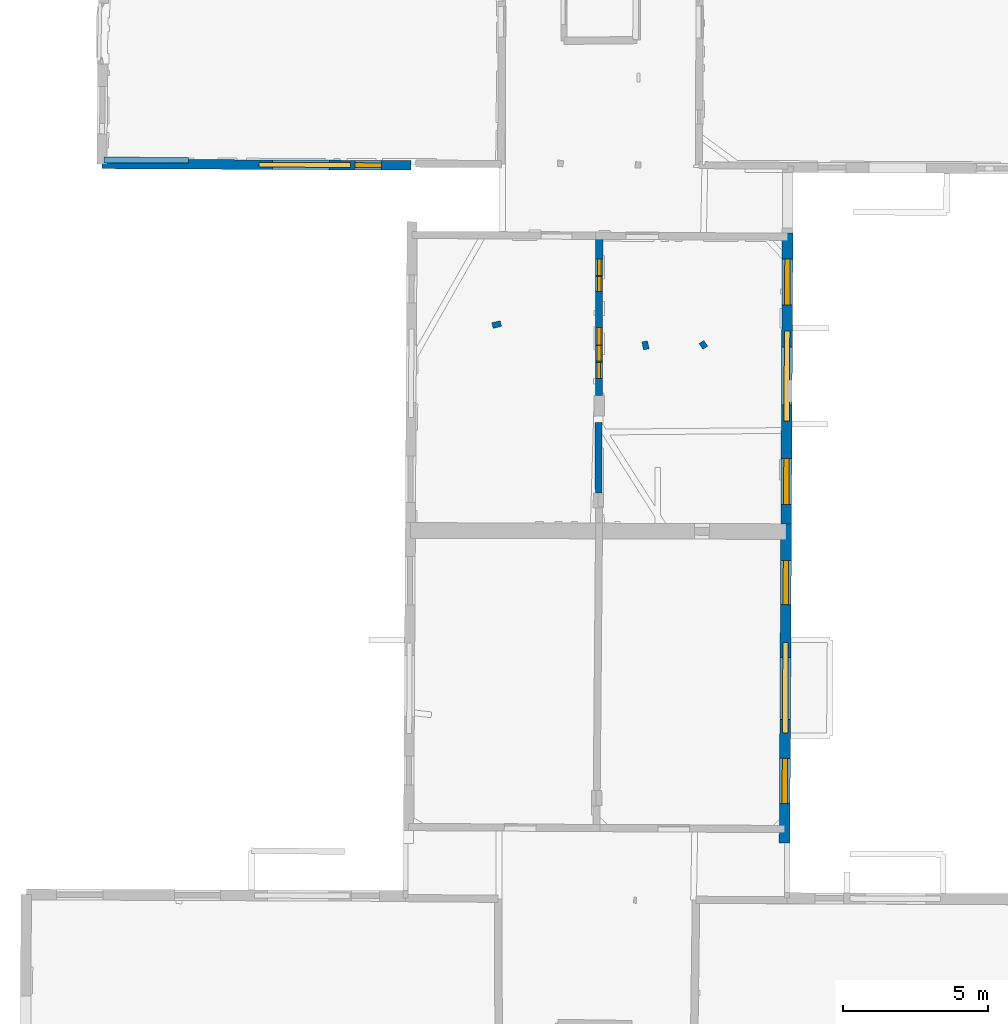
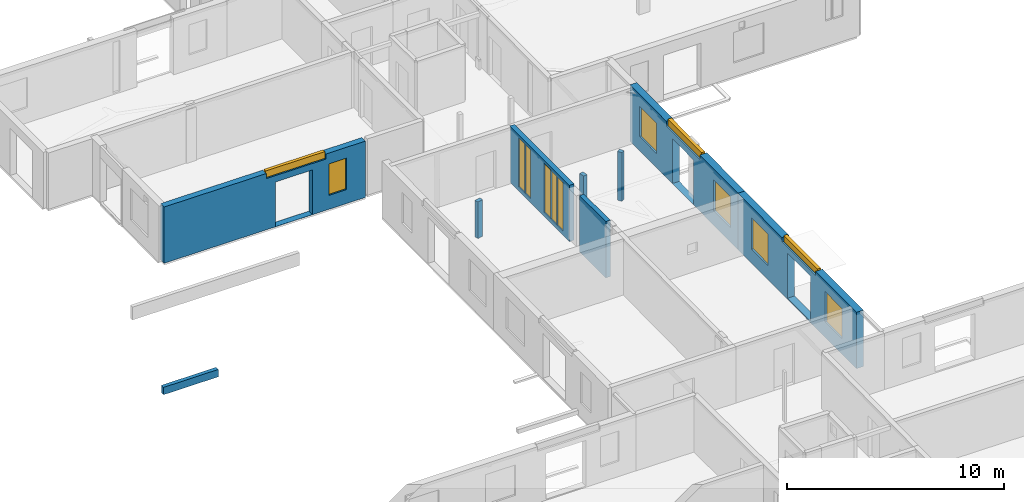
# One storey, part 7 of 17: 13 windows, 9 walls, 16 openings.
"""IFC2X3 building model written with IfcOpenShell, lengths in metres."""

from ifc_helpers import new_model, entity, si_unit, converted_unit, derived_unit, direction, frame, frame_2d, origin, origin_2d_with_axis, place, context, subcontext, project, spatial, polyline, rectangle, outline, extrude, source, transform, mapped, material, layer, layer_set, layer_usage, type_object, type_shapes, element, fill, save


model = new_model("IFC2X3")

# Units and contexts
model_context = context("Model", 3, precision=1e-05, world=origin(), true_north=direction((0.0, 1.0)))
body_context = subcontext(model_context, "Body", "Model", "MODEL_VIEW")
ifc_project = project(units=[si_unit("LENGTHUNIT", "METRE"), si_unit("AREAUNIT", "SQUARE_METRE"), si_unit("VOLUMEUNIT", "CUBIC_METRE"), converted_unit("PLANEANGLEUNIT", "DEGREE", entity("IfcRatioMeasure", 0.0174532925199433), si_unit("PLANEANGLEUNIT", "RADIAN"), dimensions=[0, 0, 0, 0, 0, 0, 0]), si_unit("MASSUNIT", "GRAM", prefix="KILO"), derived_unit("MASSDENSITYUNIT", [(si_unit("MASSUNIT", "GRAM", prefix="KILO"), 1), (si_unit("LENGTHUNIT", "METRE"), -3)]), derived_unit("MOMENTOFINERTIAUNIT", [(si_unit("LENGTHUNIT", "METRE"), 4)]), si_unit("TIMEUNIT", "SECOND"), si_unit("FREQUENCYUNIT", "HERTZ"), si_unit("THERMODYNAMICTEMPERATUREUNIT", "DEGREE_CELSIUS"), derived_unit("THERMALTRANSMITTANCEUNIT", [(si_unit("MASSUNIT", "GRAM", prefix="KILO"), 1), (si_unit("THERMODYNAMICTEMPERATUREUNIT", "KELVIN"), -1), (si_unit("TIMEUNIT", "SECOND"), -3)]), derived_unit("VOLUMETRICFLOWRATEUNIT", [(si_unit("LENGTHUNIT", "METRE"), 3), (si_unit("TIMEUNIT", "SECOND"), -1)]), si_unit("ELECTRICCURRENTUNIT", "AMPERE"), si_unit("ELECTRICVOLTAGEUNIT", "VOLT"), si_unit("POWERUNIT", "WATT"), si_unit("FORCEUNIT", "NEWTON", prefix="KILO"), si_unit("ILLUMINANCEUNIT", "LUX"), si_unit("LUMINOUSFLUXUNIT", "LUMEN"), si_unit("LUMINOUSINTENSITYUNIT", "CANDELA"), derived_unit("USERDEFINED", [(si_unit("MASSUNIT", "GRAM", prefix="KILO"), -1), (si_unit("LENGTHUNIT", "METRE"), -2), (si_unit("TIMEUNIT", "SECOND"), 3), (si_unit("LUMINOUSFLUXUNIT", "LUMEN"), 1)]), derived_unit("LINEARVELOCITYUNIT", [(si_unit("LENGTHUNIT", "METRE"), 1), (si_unit("TIMEUNIT", "SECOND"), -1)]), si_unit("PRESSUREUNIT", "PASCAL"), derived_unit("USERDEFINED", [(si_unit("LENGTHUNIT", "METRE"), -2), (si_unit("MASSUNIT", "GRAM", prefix="KILO"), 1), (si_unit("TIMEUNIT", "SECOND"), -2)]), derived_unit("LINEARFORCEUNIT", [(si_unit("MASSUNIT", "GRAM", prefix="KILO"), 1), (si_unit("LENGTHUNIT", "METRE"), 1), (si_unit("TIMEUNIT", "SECOND"), -2), (si_unit("LENGTHUNIT", "METRE"), -1)]), derived_unit("PLANARFORCEUNIT", [(si_unit("MASSUNIT", "GRAM", prefix="KILO"), 1), (si_unit("LENGTHUNIT", "METRE"), 1), (si_unit("TIMEUNIT", "SECOND"), -2), (si_unit("LENGTHUNIT", "METRE"), -2)])], contexts=[model_context])

# Site, building, storey
placement_1 = place(None, origin())
site = spatial("IfcSite", under=ifc_project, at=placement_1, CompositionType="ELEMENT")
building = spatial("IfcBuilding", under=site, at=placement_1, CompositionType="ELEMENT")
storey_placement = place(placement_1, frame((0.0, 0.0, 5.56662893295288)))
storey = spatial("IfcBuildingStorey", under=building, at=storey_placement, Name="Level 3", CompositionType="ELEMENT", Elevation=5.56662893295288)

# Wall, openings, windows
ifc_material_1 = material(Name="Default wall")
ifc_layer_1 = layer(ifc_material_1, 0.25)
ifc_layer_set_1 = layer_set([ifc_layer_1], Name="wall_thickness_0.2500")
ifc_layer_usage_1 = layer_usage(ifc_layer_set_1, "AXIS2", "POSITIVE", -0.125)
wall_type_1 = type_object("IfcWallType", Name="wall_thickness_0.2500", PredefinedType="STANDARD", material=ifc_layer_set_1)
wall_1_placement = place(storey_placement, frame((6.31279916469172, 48.7500668796256, 0.0), z_axis=(0.0, 0.0, 1.0), x_axis=(-0.00215045859313705, -0.999997687761246, 0.0)))
wall_1 = element("IfcWallStandardCase", 1, at=wall_1_placement, inside=storey, type_object=wall_type_1, material=ifc_layer_usage_1, Name="Wall:106", ObjectType="Wall", context=body_context, shape_type="SweptSolid", body=[
    extrude(outline(polyline([(5.51017509435602, -0.125), (5.51017509435602, 0.125), (0.0, 0.125), (0.0, -0.125), (5.51017509435602, -0.125)])), origin(), (0.0, 0.0, 1.0), 3.16489877700806),
])
opening_1_placement = place(wall_1_placement, frame((3.78181949815261, -0.125, 0.233371257781982)))
opening_1 = element("IfcOpeningElement", 2, at=opening_1_placement, cuts=wall_1, Name="Opening : 545 x 2710 : 102", ObjectType="Opening", context=body_context, shape_type="SweptSolid", body=[
    extrude(rectangle(XDim=0.545, YDim=2.71, at=frame_2d((1.355, 0.2725), x_axis=(0.0, 1.0))), frame((0.0, 0.0, 0.0), z_axis=(0.0, 1.0, 0.0), x_axis=(0.0, 0.0, 1.0)), (0.0, 0.0, 1.0), 0.25),
])
opening_2_placement = place(wall_1_placement, frame((4.3668199360473, -0.125, 0.233371257781982)))
opening_2 = element("IfcOpeningElement", 3, at=opening_2_placement, cuts=wall_1, Name="Opening : 555 x 2710 : 103", ObjectType="Opening", context=body_context, shape_type="SweptSolid", body=[
    extrude(rectangle(XDim=0.555, YDim=2.71, at=frame_2d((1.355, 0.2775), x_axis=(0.0, 1.0))), frame((0.0, 0.0, 0.0), z_axis=(0.0, 1.0, 0.0), x_axis=(0.0, 0.0, 1.0)), (0.0, 0.0, 1.0), 0.25),
])
opening_3_placement = place(wall_1_placement, frame((0.801820694138092, -0.125, 0.233371257781982)))
opening_3 = element("IfcOpeningElement", 4, at=opening_3_placement, cuts=wall_1, Name="Opening : 570 x 2765 : 104", ObjectType="Opening", context=body_context, shape_type="SweptSolid", body=[
    extrude(rectangle(XDim=0.57, YDim=2.765, at=frame_2d((1.3825, 0.285), x_axis=(0.0, 1.0))), frame((0.0, 0.0, 0.0), z_axis=(0.0, 1.0, 0.0), x_axis=(0.0, 0.0, 1.0)), (0.0, 0.0, 1.0), 0.25),
])
opening_4_placement = place(wall_1_placement, frame((1.41181890128605, -0.125, 0.233371257781982)))
opening_4 = element("IfcOpeningElement", 5, at=opening_4_placement, cuts=wall_1, Name="Opening : 505 x 2765 : 105", ObjectType="Opening", context=body_context, shape_type="SweptSolid", body=[
    extrude(rectangle(XDim=0.505, YDim=2.765, at=frame_2d((1.3825, 0.2525), x_axis=(0.0, 1.0))), frame((0.0, 0.0, 0.0), z_axis=(0.0, 1.0, 0.0), x_axis=(0.0, 0.0, 1.0)), (0.0, 0.0, 1.0), 0.25),
])
opening_5_placement = place(wall_1_placement, frame((3.16233030308558, -0.125, 0.221371173858643)))
opening_5 = element("IfcOpeningElement", 6, at=opening_5_placement, cuts=wall_1, Name="Opening : 600 x 2775 : 106", ObjectType="Opening", context=body_context, shape_type="SweptSolid", body=[
    extrude(rectangle(XDim=0.6, YDim=2.775, at=frame_2d((1.3875, 0.3), x_axis=(0.0, 1.0))), frame((0.0, 0.0, 0.0), z_axis=(0.0, 1.0, 0.0), x_axis=(0.0, 0.0, 1.0)), (0.0, 0.0, 1.0), 0.25),
])
ifc_material_2 = material(Name="Window Default")
window_style_1 = type_object("IfcWindowStyle", Name="Window : 545 x 2710mm", ConstructionType="NOTDEFINED", OperationType="NOTDEFINED", ParameterTakesPrecedence=False, Sizeable=False, material=ifc_material_2)
shared_shape_1 = source(origin(), body_context, "Body", "SweptSolid", [
    extrude(rectangle(XDim=0.125, YDim=0.545, at=origin_2d_with_axis()), frame((0.2725, 0.125, 0.0), z_axis=(0.0, 0.0, 1.0), x_axis=(0.0, 1.0, 0.0)), (0.0, 0.0, 1.0), 2.71),
])
type_shapes(window_style_1, [shared_shape_1])
window_1_placement = place(opening_1_placement, origin())
window_1 = element("IfcWindow", 7, at=window_1_placement, inside=storey, type_object=window_style_1, Name="Window : 545 x 2710mm : 59", ObjectType="Window : 545 x 2710mm", OverallHeight=2.71, OverallWidth=0.545, context=body_context, shape_type="MappedRepresentation", body=[
    mapped(shared_shape_1, transform((0.0, 0.0, 0.0), scale=1.0)),
])
fill(opening_1, window_1)
window_style_2 = type_object("IfcWindowStyle", Name="Window : 555 x 2710mm", ConstructionType="NOTDEFINED", OperationType="NOTDEFINED", ParameterTakesPrecedence=False, Sizeable=False, material=ifc_material_2)
shared_shape_2 = source(origin(), body_context, "Body", "SweptSolid", [
    extrude(rectangle(XDim=0.125, YDim=0.555, at=origin_2d_with_axis()), frame((0.2775, 0.125, 0.0), z_axis=(0.0, 0.0, 1.0), x_axis=(0.0, 1.0, 0.0)), (0.0, 0.0, 1.0), 2.71),
])
type_shapes(window_style_2, [shared_shape_2])
window_2_placement = place(opening_2_placement, origin())
window_2 = element("IfcWindow", 8, at=window_2_placement, inside=storey, type_object=window_style_2, Name="Window : 555 x 2710mm : 60", ObjectType="Window : 555 x 2710mm", OverallHeight=2.71, OverallWidth=0.555, context=body_context, shape_type="MappedRepresentation", body=[
    mapped(shared_shape_2, transform((0.0, 0.0, 0.0), scale=1.0)),
])
fill(opening_2, window_2)
window_style_3 = type_object("IfcWindowStyle", Name="Window : 570 x 2765mm", ConstructionType="NOTDEFINED", OperationType="NOTDEFINED", ParameterTakesPrecedence=False, Sizeable=False, material=ifc_material_2)
shared_shape_3 = source(origin(), body_context, "Body", "SweptSolid", [
    extrude(rectangle(XDim=0.125, YDim=0.57, at=origin_2d_with_axis()), frame((0.285, 0.125, 0.0), z_axis=(0.0, 0.0, 1.0), x_axis=(0.0, 1.0, 0.0)), (0.0, 0.0, 1.0), 2.765),
])
type_shapes(window_style_3, [shared_shape_3])
window_3_placement = place(opening_3_placement, origin())
window_3 = element("IfcWindow", 9, at=window_3_placement, inside=storey, type_object=window_style_3, Name="Window : 570 x 2765mm : 61", ObjectType="Window : 570 x 2765mm", OverallHeight=2.765, OverallWidth=0.57, context=body_context, shape_type="MappedRepresentation", body=[
    mapped(shared_shape_3, transform((0.0, 0.0, 0.0), scale=1.0)),
])
fill(opening_3, window_3)
window_style_4 = type_object("IfcWindowStyle", Name="Window : 505 x 2765mm", ConstructionType="NOTDEFINED", OperationType="NOTDEFINED", ParameterTakesPrecedence=False, Sizeable=False, material=ifc_material_2)
shared_shape_4 = source(origin(), body_context, "Body", "SweptSolid", [
    extrude(rectangle(XDim=0.125, YDim=0.505, at=origin_2d_with_axis()), frame((0.2525, 0.125, 0.0), z_axis=(0.0, 0.0, 1.0), x_axis=(0.0, 1.0, 0.0)), (0.0, 0.0, 1.0), 2.765),
])
type_shapes(window_style_4, [shared_shape_4])
window_4_placement = place(opening_4_placement, origin())
window_4 = element("IfcWindow", 10, at=window_4_placement, inside=storey, type_object=window_style_4, Name="Window : 505 x 2765mm : 62", ObjectType="Window : 505 x 2765mm", OverallHeight=2.765, OverallWidth=0.505, context=body_context, shape_type="MappedRepresentation", body=[
    mapped(shared_shape_4, transform((0.0, 0.0, 0.0), scale=1.0)),
])
fill(opening_4, window_4)
window_style_5 = type_object("IfcWindowStyle", Name="Window : 600 x 2775mm", ConstructionType="NOTDEFINED", OperationType="NOTDEFINED", ParameterTakesPrecedence=False, Sizeable=False, material=ifc_material_2)
shared_shape_5 = source(origin(), body_context, "Body", "SweptSolid", [
    extrude(rectangle(XDim=0.125, YDim=0.6, at=origin_2d_with_axis()), frame((0.3, 0.125, 0.0), z_axis=(0.0, 0.0, 1.0), x_axis=(0.0, 1.0, 0.0)), (0.0, 0.0, 1.0), 2.775),
])
type_shapes(window_style_5, [shared_shape_5])
window_5_placement = place(opening_5_placement, origin())
window_5 = element("IfcWindow", 11, at=window_5_placement, inside=storey, type_object=window_style_5, Name="Window : 600 x 2775mm : 63", ObjectType="Window : 600 x 2775mm", OverallHeight=2.775, OverallWidth=0.6, context=body_context, shape_type="MappedRepresentation", body=[
    mapped(shared_shape_5, transform((0.0, 0.0, 0.0), scale=1.0)),
])
fill(opening_5, window_5)

ifc_layer_2 = layer(ifc_material_1, 0.330000013113022)
ifc_layer_set_2 = layer_set([ifc_layer_2], Name="wall_thickness_0.3300")
ifc_layer_usage_2 = layer_usage(ifc_layer_set_2, "AXIS2", "POSITIVE", -0.165000006556511)
wall_type_2 = type_object("IfcWallType", Name="wall_thickness_0.3300", PredefinedType="STANDARD", material=ifc_layer_set_2)
wall_2_placement = place(storey_placement, frame((-10.8574823928205, 51.2321673853361, 0.0), z_axis=(0.0, 0.0, 1.0), x_axis=(0.999989023778504, -0.00468533056625142, 0.0)))
wall_2 = element("IfcWallStandardCase", 12, at=wall_2_placement, inside=storey, type_object=wall_type_2, material=ifc_layer_usage_2, Name="Wall:105", ObjectType="Wall", context=body_context, shape_type="SweptSolid", body=[
    extrude(outline(polyline([(10.6771420359845, -0.165000006556511), (10.6771420359845, 0.165000006556511), (0.0, 0.165000006556511), (0.0, -0.165000006556511), (10.6771420359845, -0.165000006556511)])), origin(), (0.0, 0.0, 1.0), 3.16489877700806),
])
opening_6_placement = place(wall_2_placement, frame((5.89679331498811, -0.165000006556511, 0.00537109375)))
element("IfcOpeningElement", 13, at=opening_6_placement, cuts=wall_2, Name="Opening : 1965 x 2515 : 99", ObjectType="Opening", context=body_context, shape_type="SweptSolid", body=[
    extrude(rectangle(XDim=1.965, YDim=2.515, at=frame_2d((1.2575, 0.9825), x_axis=(0.0, 1.0))), frame((0.0, 0.0, 0.0), z_axis=(0.0, 1.0, 0.0), x_axis=(0.0, 0.0, 1.0)), (0.0, 0.0, 1.0), 0.330000013113022),
])
opening_7_placement = place(wall_2_placement, frame((5.42679313914859, -0.165000006556511, 2.88037061691284)))
opening_7 = element("IfcOpeningElement", 14, at=opening_7_placement, cuts=wall_2, Name="Opening : 3155 x 375 : 100", ObjectType="Opening", context=body_context, shape_type="SweptSolid", body=[
    extrude(rectangle(XDim=3.155, YDim=0.375, at=frame_2d((0.1875, 1.5775), x_axis=(0.0, 1.0))), frame((0.0, 0.0, 0.0), z_axis=(0.0, 1.0, 0.0), x_axis=(0.0, 0.0, 1.0)), (0.0, 0.0, 1.0), 0.330000013113022),
])
opening_8_placement = place(wall_2_placement, frame((8.7317939524994, -0.165000006556511, 0.785370826721191)))
opening_8 = element("IfcOpeningElement", 15, at=opening_8_placement, cuts=wall_2, Name="Opening : 930 x 1770 : 101", ObjectType="Opening", context=body_context, shape_type="SweptSolid", body=[
    extrude(rectangle(XDim=0.93, YDim=1.77, at=frame_2d((0.885, 0.465), x_axis=(0.0, 1.0))), frame((0.0, 0.0, 0.0), z_axis=(0.0, 1.0, 0.0), x_axis=(0.0, 0.0, 1.0)), (0.0, 0.0, 1.0), 0.330000013113022),
])
window_style_6 = type_object("IfcWindowStyle", Name="Window : 3155 x 375mm", ConstructionType="NOTDEFINED", OperationType="NOTDEFINED", ParameterTakesPrecedence=False, Sizeable=False, material=ifc_material_2)
shared_shape_6 = source(origin(), body_context, "Body", "SweptSolid", [
    extrude(rectangle(XDim=0.165000006556511, YDim=3.155, at=origin_2d_with_axis()), frame((1.5775, 0.165000006556511, 0.0), z_axis=(0.0, 0.0, 1.0), x_axis=(0.0, 1.0, 0.0)), (0.0, 0.0, 1.0), 0.375),
])
type_shapes(window_style_6, [shared_shape_6])
window_6_placement = place(opening_7_placement, origin())
window_6 = element("IfcWindow", 16, at=window_6_placement, inside=storey, type_object=window_style_6, Name="Window : 3155 x 375mm : 57", ObjectType="Window : 3155 x 375mm", OverallHeight=0.375, OverallWidth=3.155, context=body_context, shape_type="MappedRepresentation", body=[
    mapped(shared_shape_6, transform((0.0, 0.0, 0.0), scale=1.0)),
])
fill(opening_7, window_6)
window_style_7 = type_object("IfcWindowStyle", Name="Window : 930 x 1770mm", ConstructionType="NOTDEFINED", OperationType="NOTDEFINED", ParameterTakesPrecedence=False, Sizeable=False, material=ifc_material_2)
shared_shape_7 = source(origin(), body_context, "Body", "SweptSolid", [
    extrude(rectangle(XDim=0.165000006556511, YDim=0.93, at=origin_2d_with_axis()), frame((0.465, 0.165000006556511, 0.0), z_axis=(0.0, 0.0, 1.0), x_axis=(0.0, 1.0, 0.0)), (0.0, 0.0, 1.0), 1.77),
])
type_shapes(window_style_7, [shared_shape_7])
window_7_placement = place(opening_8_placement, origin())
window_7 = element("IfcWindow", 17, at=window_7_placement, inside=storey, type_object=window_style_7, Name="Window : 930 x 1770mm : 58", ObjectType="Window : 930 x 1770mm", OverallHeight=1.77, OverallWidth=0.93, context=body_context, shape_type="MappedRepresentation", body=[
    mapped(shared_shape_7, transform((0.0, 0.0, 0.0), scale=1.0)),
])
fill(opening_8, window_7)

# Walls
ifc_layer_3 = layer(ifc_material_1, 0.2)
ifc_layer_set_3 = layer_set([ifc_layer_3], Name="wall_thickness_0.2000")
ifc_layer_usage_3 = layer_usage(ifc_layer_set_3, "AXIS2", "POSITIVE", -0.1)
wall_type_3 = type_object("IfcWallType", Name="wall_thickness_0.2000", PredefinedType="STANDARD", material=ifc_layer_set_3)
wall_3_placement = place(storey_placement, frame((2.91970988708181, 45.7200888669237, 0.0), z_axis=(0.0, 0.0, 1.0), x_axis=(-0.973624263711592, -0.228157386713776, 0.0)))
element("IfcWallStandardCase", 18, at=wall_3_placement, inside=storey, type_object=wall_type_3, material=ifc_layer_usage_3, Name="Wall:30", ObjectType="Wall", context=body_context, shape_type="SweptSolid", body=[
    extrude(outline(polyline([(0.299999548657947, -0.1), (0.299999548657947, 0.1), (0.0, 0.1), (0.0, -0.1), (0.299999548657947, -0.1)])), origin(), (0.0, 0.0, 1.0), 2.0533709526062),
])
wall_4_placement = place(storey_placement, frame((7.9404242124178, 44.8287967823806, 0.0), z_axis=(0.0, 0.0, 1.0), x_axis=(-0.205539860713421, 0.978648744779202, 0.0)))
element("IfcWallStandardCase", 19, at=wall_4_placement, inside=storey, type_object=wall_type_3, material=ifc_layer_usage_3, Name="Wall:37", ObjectType="Wall", context=body_context, shape_type="SweptSolid", body=[
    extrude(outline(polyline([(0.285000524203774, -0.1), (0.285000524203774, 0.1), (0.0, 0.1), (0.0, -0.1), (0.285000524203774, -0.1)])), origin(), (0.0, 0.0, 1.0), 2.15437078475952),
])
wall_5_placement = place(storey_placement, frame((9.84112033782494, 45.0825052257166, 0.0), z_axis=(0.0, 0.0, 1.0), x_axis=(0.56271547253401, -0.826650649894395, 0.0)))
element("IfcWallStandardCase", 20, at=wall_5_placement, inside=storey, type_object=wall_type_3, material=ifc_layer_usage_3, Name="Wall:92", ObjectType="Wall", context=body_context, shape_type="SweptSolid", body=[
    extrude(outline(polyline([(0.239998329906315, -0.1), (0.239998329906315, 0.1), (0.0, 0.1), (0.0, -0.1), (0.239998329906315, -0.1)])), origin(), (0.0, 0.0, 1.0), 2.7383713722229),
])
placement_2 = place(placement_1, frame((0.0, 0.0, -1.97499942779541)))
wall_6_placement = place(placement_2, frame((-10.780126569897, 51.3657368461269, 0.0), z_axis=(0.0, 0.0, 1.0), x_axis=(0.999995431962856, -0.00302259051491604, 0.0)))
element("IfcWallStandardCase", 21, at=wall_6_placement, inside=storey, type_object=wall_type_3, material=ifc_layer_usage_3, Name="Wall:850", ObjectType="Wall", context=body_context, shape_type="SweptSolid", body=[
    extrude(outline(polyline([(2.91031545659952, -0.1), (2.91031545659952, 0.1), (0.0, 0.1), (0.0, -0.1), (2.91031545659952, -0.1)])), origin(), (0.0, 0.0, 1.0), 0.4137460231781),
])
ifc_layer_4 = layer(ifc_material_1, 0.239999994635582)
ifc_layer_set_4 = layer_set([ifc_layer_4], Name="wall_thickness_0.2400")
ifc_layer_usage_4 = layer_usage(ifc_layer_set_4, "AXIS2", "POSITIVE", -0.119999997317791)
wall_type_4 = type_object("IfcWallType", Name="wall_thickness_0.2400", PredefinedType="STANDARD", material=ifc_layer_set_4)
wall_7_placement = place(storey_placement, frame((6.28554615701016, 42.3039906956822, 0.0), z_axis=(0.0, 0.0, 1.0), x_axis=(0.00449270702895181, -0.999989907740849, 0.0)))
element("IfcWallStandardCase", 22, at=wall_7_placement, inside=storey, type_object=wall_type_4, material=ifc_layer_usage_4, Name="Wall:28", ObjectType="Wall", context=body_context, shape_type="SweptSolid", body=[
    extrude(outline(polyline([(2.42828149537153, -0.119999997317791), (2.42828149537153, 0.119999997317791), (0.0, 0.119999997317791), (0.0, -0.119999997317791), (2.42828149537153, -0.119999997317791)])), origin(), (0.0, 0.0, 1.0), 3.16489877700806),
])

# Wall, openings, windows
ifc_layer_5 = layer(ifc_material_1, 0.370000004768372)
ifc_layer_set_5 = layer_set([ifc_layer_5], Name="wall_thickness_0.3700")
ifc_layer_usage_5 = layer_usage(ifc_layer_set_5, "AXIS2", "POSITIVE", -0.185000002384186)
wall_type_5 = type_object("IfcWallType", Name="wall_thickness_0.3700", PredefinedType="STANDARD", material=ifc_layer_set_5)
wall_8_placement = place(storey_placement, frame((12.8154790997918, 48.8437880711445, 0.0), z_axis=(0.0, 0.0, 1.0), x_axis=(-0.00494841806333359, -0.999987756504384, 0.0)))
wall_8 = element("IfcWallStandardCase", 23, at=wall_8_placement, inside=storey, type_object=wall_type_5, material=ifc_layer_usage_5, Name="Wall:52", ObjectType="Wall", context=body_context, shape_type="SweptSolid", body=[
    extrude(outline(polyline([(10.0352829316398, -0.185000002384186), (10.0352829316398, 0.185000002384186), (0.0, 0.185000002384186), (0.0, -0.185000002384186), (10.0352829316398, -0.185000002384186)])), origin(), (0.0, 0.0, 1.0), 3.16489877700806),
])
opening_9_placement = place(wall_8_placement, frame((3.93930679932947, -0.185000002384186, 0.00537109375)))
element("IfcOpeningElement", 24, at=opening_9_placement, cuts=wall_8, Name="Opening : 1990 x 2520 : 41", ObjectType="Opening", context=body_context, shape_type="SweptSolid", body=[
    extrude(rectangle(XDim=1.99, YDim=2.52, at=frame_2d((1.26, 0.995), x_axis=(0.0, 1.0))), frame((0.0, 0.0, 0.0), z_axis=(0.0, 1.0, 0.0), x_axis=(0.0, 0.0, 1.0)), (0.0, 0.0, 1.0), 0.370000004768372),
])
opening_10_placement = place(wall_8_placement, frame((0.894305680629351, -0.185000002384186, 0.800370693206787)))
opening_10 = element("IfcOpeningElement", 25, at=opening_10_placement, cuts=wall_8, Name="Opening : 1580 x 1710 : 42", ObjectType="Opening", context=body_context, shape_type="SweptSolid", body=[
    extrude(rectangle(XDim=1.58, YDim=1.71, at=frame_2d((0.855, 0.79), x_axis=(0.0, 1.0))), frame((0.0, 0.0, 0.0), z_axis=(0.0, 1.0, 0.0), x_axis=(0.0, 0.0, 1.0)), (0.0, 0.0, 1.0), 0.370000004768372),
])
opening_11_placement = place(wall_8_placement, frame((3.3797830479759, -0.185000002384186, 2.8953709602356)))
opening_11 = element("IfcOpeningElement", 26, at=opening_11_placement, cuts=wall_8, Name="Opening : 3110 x 360 : 43", ObjectType="Opening", context=body_context, shape_type="SweptSolid", body=[
    extrude(rectangle(XDim=3.11, YDim=0.36, at=frame_2d((0.18, 1.555), x_axis=(0.0, 1.0))), frame((0.0, 0.0, 0.0), z_axis=(0.0, 1.0, 0.0), x_axis=(0.0, 0.0, 1.0)), (0.0, 0.0, 1.0), 0.370000004768372),
])
opening_12_placement = place(wall_8_placement, frame((7.77430706114809, -0.185000002384186, 0.815371036529541)))
opening_12 = element("IfcOpeningElement", 27, at=opening_12_placement, cuts=wall_8, Name="Opening : 1590 x 1725 : 44", ObjectType="Opening", context=body_context, shape_type="SweptSolid", body=[
    extrude(rectangle(XDim=1.59, YDim=1.725, at=frame_2d((0.8625, 0.795), x_axis=(0.0, 1.0))), frame((0.0, 0.0, 0.0), z_axis=(0.0, 1.0, 0.0), x_axis=(0.0, 0.0, 1.0)), (0.0, 0.0, 1.0), 0.370000004768372),
])
window_style_8 = type_object("IfcWindowStyle", Name="Window : 1580 x 1710mm", ConstructionType="NOTDEFINED", OperationType="NOTDEFINED", ParameterTakesPrecedence=False, Sizeable=False, material=ifc_material_2)
shared_shape_8 = source(origin(), body_context, "Body", "SweptSolid", [
    extrude(rectangle(XDim=0.185000002384186, YDim=1.58, at=origin_2d_with_axis()), frame((0.79, 0.185000002384186, 0.0), z_axis=(0.0, 0.0, 1.0), x_axis=(0.0, 1.0, 0.0)), (0.0, 0.0, 1.0), 1.71),
])
type_shapes(window_style_8, [shared_shape_8])
window_8_placement = place(opening_10_placement, origin())
window_8 = element("IfcWindow", 28, at=window_8_placement, inside=storey, type_object=window_style_8, Name="Window : 1580 x 1710mm : 22", ObjectType="Window : 1580 x 1710mm", OverallHeight=1.71, OverallWidth=1.58, context=body_context, shape_type="MappedRepresentation", body=[
    mapped(shared_shape_8, transform((0.0, 0.0, 0.0), scale=1.0)),
])
fill(opening_10, window_8)
window_style_9 = type_object("IfcWindowStyle", Name="Window : 3110 x 360mm", ConstructionType="NOTDEFINED", OperationType="NOTDEFINED", ParameterTakesPrecedence=False, Sizeable=False, material=ifc_material_2)
shared_shape_9 = source(origin(), body_context, "Body", "SweptSolid", [
    extrude(rectangle(XDim=0.185000002384186, YDim=3.11, at=origin_2d_with_axis()), frame((1.555, 0.185000002384186, 0.0), z_axis=(0.0, 0.0, 1.0), x_axis=(0.0, 1.0, 0.0)), (0.0, 0.0, 1.0), 0.36),
])
type_shapes(window_style_9, [shared_shape_9])
window_9_placement = place(opening_11_placement, origin())
window_9 = element("IfcWindow", 29, at=window_9_placement, inside=storey, type_object=window_style_9, Name="Window : 3110 x 360mm : 23", ObjectType="Window : 3110 x 360mm", OverallHeight=0.36, OverallWidth=3.11, context=body_context, shape_type="MappedRepresentation", body=[
    mapped(shared_shape_9, transform((0.0, 0.0, 0.0), scale=1.0)),
])
fill(opening_11, window_9)
window_style_10 = type_object("IfcWindowStyle", Name="Window : 1590 x 1725mm", ConstructionType="NOTDEFINED", OperationType="NOTDEFINED", ParameterTakesPrecedence=False, Sizeable=False, material=ifc_material_2)
shared_shape_10 = source(origin(), body_context, "Body", "SweptSolid", [
    extrude(rectangle(XDim=0.185000002384186, YDim=1.59, at=origin_2d_with_axis()), frame((0.795, 0.185000002384186, 0.0), z_axis=(0.0, 0.0, 1.0), x_axis=(0.0, 1.0, 0.0)), (0.0, 0.0, 1.0), 1.725),
])
type_shapes(window_style_10, [shared_shape_10])
window_10_placement = place(opening_12_placement, origin())
window_10 = element("IfcWindow", 30, at=window_10_placement, inside=storey, type_object=window_style_10, Name="Window : 1590 x 1725mm : 24", ObjectType="Window : 1590 x 1725mm", OverallHeight=1.725, OverallWidth=1.59, context=body_context, shape_type="MappedRepresentation", body=[
    mapped(shared_shape_10, transform((0.0, 0.0, 0.0), scale=1.0)),
])
fill(opening_12, window_10)

wall_9_placement = place(storey_placement, frame((12.7658203244623, 38.8086280064472, 0.0), z_axis=(0.0, 0.0, 1.0), x_axis=(-0.0049484007711038, -0.999987756589954, 0.0)))
wall_9 = element("IfcWallStandardCase", 31, at=wall_9_placement, inside=storey, type_object=wall_type_5, material=ifc_layer_usage_5, Name="Wall:53", ObjectType="Wall", context=body_context, shape_type="SweptSolid", body=[
    extrude(outline(polyline([(11.0131982698885, -0.185000002384186), (11.0131982698885, 0.185000002384186), (0.0, 0.185000002384186), (0.0, -0.185000002384186), (11.0131982698885, -0.185000002384186)])), origin(), (0.0, 0.0, 1.0), 3.16489877700806),
])
opening_13_placement = place(wall_9_placement, frame((4.6100456040055, -0.185000002384186, 0.0713710784912109)))
element("IfcOpeningElement", 32, at=opening_13_placement, cuts=wall_9, Name="Opening : 2140 x 2530 : 45", ObjectType="Opening", context=body_context, shape_type="SweptSolid", body=[
    extrude(rectangle(XDim=2.14, YDim=2.53, at=frame_2d((1.265, 1.07), x_axis=(0.0, 1.0))), frame((0.0, 0.0, 0.0), z_axis=(0.0, 1.0, 0.0), x_axis=(0.0, 0.0, 1.0)), (0.0, 0.0, 1.0), 0.370000004768372),
])
opening_14_placement = place(wall_9_placement, frame((1.25902572801302, -0.185000002384186, 0.785370826721191)))
opening_14 = element("IfcOpeningElement", 33, at=opening_14_placement, cuts=wall_9, Name="Opening : 1535 x 1785 : 46", ObjectType="Opening", context=body_context, shape_type="SweptSolid", body=[
    extrude(rectangle(XDim=1.535, YDim=1.785, at=frame_2d((0.8925, 0.7675), x_axis=(0.0, 1.0))), frame((0.0, 0.0, 0.0), z_axis=(0.0, 1.0, 0.0), x_axis=(0.0, 0.0, 1.0)), (0.0, 0.0, 1.0), 0.370000004768372),
])
opening_15_placement = place(wall_9_placement, frame((4.09837399963797, -0.185000002384186, 2.92537069320679)))
opening_15 = element("IfcOpeningElement", 34, at=opening_15_placement, cuts=wall_9, Name="Opening : 3115 x 330 : 47", ObjectType="Opening", context=body_context, shape_type="SweptSolid", body=[
    extrude(rectangle(XDim=3.115, YDim=0.33, at=frame_2d((0.165, 1.5575), x_axis=(0.0, 1.0))), frame((0.0, 0.0, 0.0), z_axis=(0.0, 1.0, 0.0), x_axis=(0.0, 0.0, 1.0)), (0.0, 0.0, 1.0), 0.370000004768372),
])
opening_16_placement = place(wall_9_placement, frame((8.09402647890812, -0.185000002384186, 0.855370998382568)))
opening_16 = element("IfcOpeningElement", 35, at=opening_16_placement, cuts=wall_9, Name="Opening : 1565 x 1710 : 48", ObjectType="Opening", context=body_context, shape_type="SweptSolid", body=[
    extrude(rectangle(XDim=1.565, YDim=1.71, at=frame_2d((0.855, 0.7825), x_axis=(0.0, 1.0))), frame((0.0, 0.0, 0.0), z_axis=(0.0, 1.0, 0.0), x_axis=(0.0, 0.0, 1.0)), (0.0, 0.0, 1.0), 0.370000004768372),
])
window_style_11 = type_object("IfcWindowStyle", Name="Window : 1535 x 1785mm", ConstructionType="NOTDEFINED", OperationType="NOTDEFINED", ParameterTakesPrecedence=False, Sizeable=False, material=ifc_material_2)
shared_shape_11 = source(origin(), body_context, "Body", "SweptSolid", [
    extrude(rectangle(XDim=0.185000002384186, YDim=1.535, at=origin_2d_with_axis()), frame((0.7675, 0.185000002384186, 0.0), z_axis=(0.0, 0.0, 1.0), x_axis=(0.0, 1.0, 0.0)), (0.0, 0.0, 1.0), 1.785),
])
type_shapes(window_style_11, [shared_shape_11])
window_11_placement = place(opening_14_placement, origin())
window_11 = element("IfcWindow", 36, at=window_11_placement, inside=storey, type_object=window_style_11, Name="Window : 1535 x 1785mm : 25", ObjectType="Window : 1535 x 1785mm", OverallHeight=1.785, OverallWidth=1.535, context=body_context, shape_type="MappedRepresentation", body=[
    mapped(shared_shape_11, transform((0.0, 0.0, 0.0), scale=1.0)),
])
fill(opening_14, window_11)
window_style_12 = type_object("IfcWindowStyle", Name="Window : 3115 x 330mm", ConstructionType="NOTDEFINED", OperationType="NOTDEFINED", ParameterTakesPrecedence=False, Sizeable=False, material=ifc_material_2)
shared_shape_12 = source(origin(), body_context, "Body", "SweptSolid", [
    extrude(rectangle(XDim=0.185000002384186, YDim=3.115, at=origin_2d_with_axis()), frame((1.5575, 0.185000002384186, 0.0), z_axis=(0.0, 0.0, 1.0), x_axis=(0.0, 1.0, 0.0)), (0.0, 0.0, 1.0), 0.33),
])
type_shapes(window_style_12, [shared_shape_12])
window_12_placement = place(opening_15_placement, origin())
window_12 = element("IfcWindow", 37, at=window_12_placement, inside=storey, type_object=window_style_12, Name="Window : 3115 x 330mm : 26", ObjectType="Window : 3115 x 330mm", OverallHeight=0.33, OverallWidth=3.115, context=body_context, shape_type="MappedRepresentation", body=[
    mapped(shared_shape_12, transform((0.0, 0.0, 0.0), scale=1.0)),
])
fill(opening_15, window_12)
window_style_13 = type_object("IfcWindowStyle", Name="Window : 1565 x 1710mm", ConstructionType="NOTDEFINED", OperationType="NOTDEFINED", ParameterTakesPrecedence=False, Sizeable=False, material=ifc_material_2)
shared_shape_13 = source(origin(), body_context, "Body", "SweptSolid", [
    extrude(rectangle(XDim=0.185000002384186, YDim=1.565, at=origin_2d_with_axis()), frame((0.7825, 0.185000002384186, 0.0), z_axis=(0.0, 0.0, 1.0), x_axis=(0.0, 1.0, 0.0)), (0.0, 0.0, 1.0), 1.71),
])
type_shapes(window_style_13, [shared_shape_13])
window_13_placement = place(opening_16_placement, origin())
window_13 = element("IfcWindow", 38, at=window_13_placement, inside=storey, type_object=window_style_13, Name="Window : 1565 x 1710mm : 27", ObjectType="Window : 1565 x 1710mm", OverallHeight=1.71, OverallWidth=1.565, context=body_context, shape_type="MappedRepresentation", body=[
    mapped(shared_shape_13, transform((0.0, 0.0, 0.0), scale=1.0)),
])
fill(opening_16, window_13)

save(model, "model.ifc")
